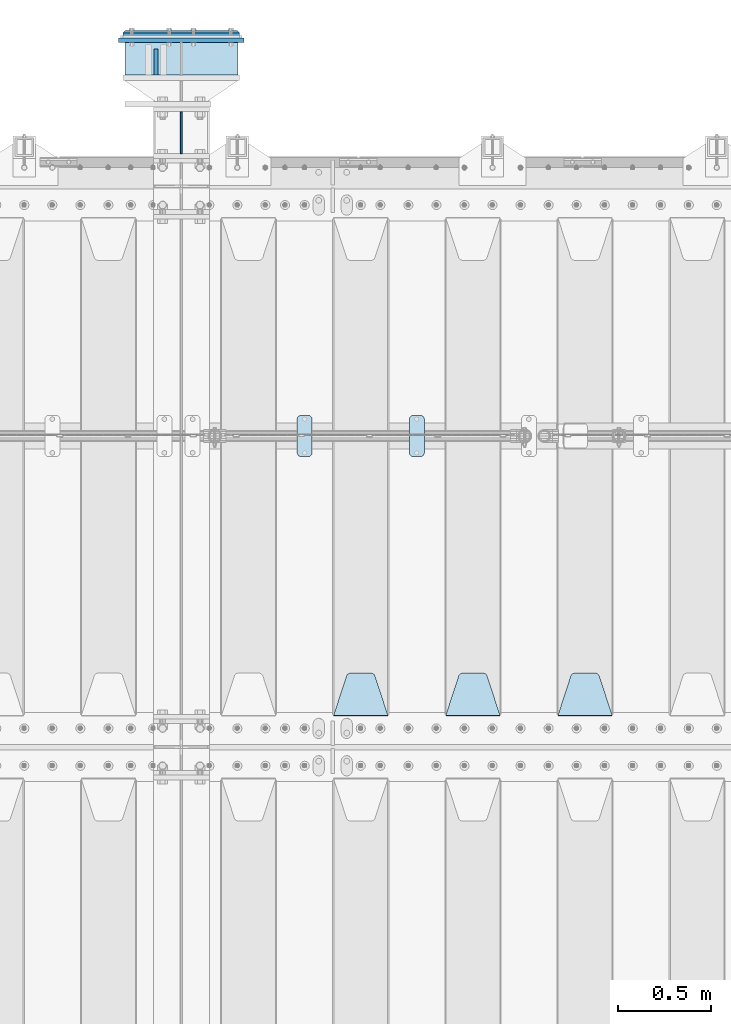
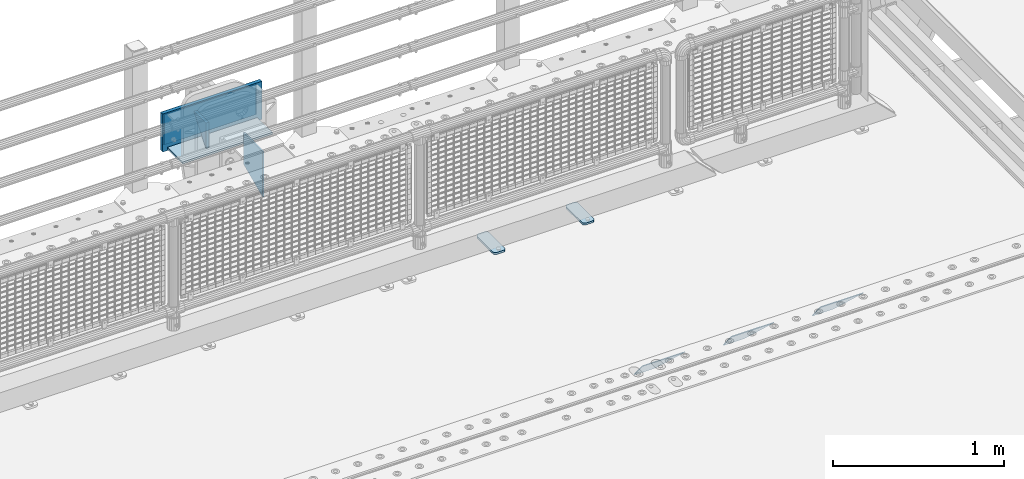
# One storey, part 176 of 193: 10 plates.
"""IFC2X3 building model written with IfcOpenShell, lengths in millimetres."""

from ifc_helpers import new_model, si_unit, frame, origin_with_axes, place, context, subcontext, project, spatial, faceted_brep, material, type_object, element, save


model = new_model("IFC2X3")

# Units and contexts
model_context = context("Model", 3, precision=1e-05, world=origin_with_axes())
body_context = subcontext(model_context, "Body", "Model", "MODEL_VIEW")
ifc_project = project(units=[si_unit("LENGTHUNIT", "METRE", prefix="MILLI"), si_unit("AREAUNIT", "SQUARE_METRE"), si_unit("VOLUMEUNIT", "CUBIC_METRE"), si_unit("MASSUNIT", "GRAM", prefix="KILO"), si_unit("TIMEUNIT", "SECOND"), si_unit("PLANEANGLEUNIT", "RADIAN"), si_unit("SOLIDANGLEUNIT", "STERADIAN"), si_unit("THERMODYNAMICTEMPERATUREUNIT", "DEGREE_CELSIUS"), si_unit("LUMINOUSINTENSITYUNIT", "LUMEN")], contexts=[model_context])

# Site, building, storey
site_placement = place(None, origin_with_axes())
site = spatial("IfcSite", under=ifc_project, at=site_placement, CompositionType="ELEMENT")
building_placement = place(site_placement, origin_with_axes())
building = spatial("IfcBuilding", under=site, at=building_placement, Name="Standard", CompositionType="ELEMENT")
storey_placement = place(building_placement, origin_with_axes())
storey = spatial("IfcBuildingStorey", under=building, at=storey_placement, Name="Undefined", CompositionType="ELEMENT", Elevation=0.0)

# Plates
ifc_material_1 = material(Name="STEEL/S355N")
plate_type_1 = type_object("IfcPlateType", PredefinedType="NOTDEFINED")
plate_1_placement = place(storey_placement, frame((-32195.5000000678, 30735.0000000043, -14.0000182383294), z_axis=(0.0, 0.0, -1.0), x_axis=(0.0, -1.0, 0.0)))
element("IfcPlate", 1, at=plate_1_placement, inside=storey, type_object=plate_type_1, material=ifc_material_1, context=body_context, shape_type="Brep", body=[
    faceted_brep([(0.0, -10.0, 0.0), (140.0, -10.0, 180.0), (140.0, 10.0, 180.0), (0.0, 10.0, 0.0), (140.0, -10.0, -1.81898940354586e-12), (140.0, 10.0, -1.81898940354586e-12)], [[[0, 1, 2, 3]], [[1, 4, 5, 2]], [[4, 0, 3, 5]], [[5, 3, 2]], [[4, 1, 0]]]),
])
plate_type_2 = type_object("IfcPlateType", PredefinedType="NOTDEFINED")
plate_2_placement = place(storey_placement, frame((-29755.0, 27168.232233047, -1.76776695296758), z_axis=(0.0, 0.707106781186547, -0.707106781186548), x_axis=(-1.0, 0.0, 0.0)))
element("IfcPlate", 2, at=plate_2_placement, inside=storey, type_object=plate_type_2, material=ifc_material_1, context=body_context, shape_type="Brep", body=[
    faceted_brep([(0.0, -2.5, 0.0), (69.345504679477, -2.50000000000364, 300.171731424831), (69.345504679477, 2.49999999999636, 300.171731424831), (0.0, 2.5, 0.0), (70.9274061199576, -2.50000000000364, 304.897442415397), (70.9274061199576, 2.49999999999636, 304.897442415397), (73.3818627772307, -2.50000000000364, 309.234538108529), (73.3818627772307, 2.49999999999636, 309.234538108529), (76.6187032999551, -2.50000000000728, 313.023683126103), (76.6187032999551, 2.49999999999636, 313.023683126103), (80.5190132704993, -2.50000000000364, 316.125672595372), (80.5190132704993, 2.49999999999636, 316.125672595368), (84.9395038596849, -2.50000000000364, 318.426546230472), (84.9395038596849, 2.49999999999636, 318.426546230476), (89.7177759439219, -2.50000000000364, 319.841774983273), (89.7177759439219, 2.49999999999636, 319.841774983277), (94.678286292652, -2.50000000000364, 320.319366455074), (94.678286292652, 2.49999999999636, 320.319366455074), (195.321713707348, -2.50000000000364, 320.319366455074), (195.321713707348, 2.49999999999636, 320.319366455074), (200.282224056078, -2.50000000000364, 319.841774983273), (200.282224056078, 2.49999999999636, 319.841774983277), (205.060496140315, -2.50000000000364, 318.426546230472), (205.060496140315, 2.49999999999636, 318.426546230472), (209.480986729501, -2.50000000000364, 316.125672595372), (209.480986729501, 2.49999999999636, 316.125672595368), (213.381296700045, -2.50000000000728, 313.023683126103), (213.381296700045, 2.49999999999272, 313.023683126103), (216.618137222769, -2.50000000000364, 309.234538108525), (216.618137222769, 2.49999999999636, 309.234538108522), (219.072593880042, -2.50000000000364, 304.897442415397), (219.072593880042, 2.49999999999636, 304.897442415397), (220.654495320523, -2.50000000000364, 300.171731424831), (220.654495320523, 2.49999999999636, 300.171731424831), (290.0, -2.50000000000364, 0.0), (290.0, 2.49999999999636, 0.0)], [[[0, 1, 2, 3]], [[1, 4, 5, 2]], [[4, 6, 7, 5]], [[6, 8, 9, 7]], [[8, 10, 11, 9]], [[10, 12, 13, 11]], [[12, 14, 15, 13]], [[14, 16, 17, 15]], [[16, 18, 19, 17]], [[18, 20, 21, 19]], [[20, 22, 23, 21]], [[22, 24, 25, 23]], [[24, 26, 27, 25]], [[26, 28, 29, 27]], [[28, 30, 31, 29]], [[30, 32, 33, 31]], [[32, 34, 35, 33]], [[34, 0, 3, 35]], [[5, 7, 9, 11, 13, 15, 17, 19, 21, 23, 25, 27, 29, 31, 33, 35, 3, 2]], [[34, 32, 30, 28, 26, 24, 22, 20, 18, 16, 14, 12, 10, 8, 6, 4, 1, 0]]]),
])
plate_3_placement = place(storey_placement, frame((-30355.0, 27168.232233047, -1.76776695296758), z_axis=(0.0, 0.707106781186547, -0.707106781186548), x_axis=(-1.0, 0.0, 0.0)))
element("IfcPlate", 3, at=plate_3_placement, inside=storey, type_object=plate_type_2, material=ifc_material_1, context=body_context, shape_type="Brep", body=[
    faceted_brep([(0.0, -2.5, 0.0), (69.345504679477, -2.50000000000364, 300.171731424831), (69.345504679477, 2.49999999999636, 300.171731424831), (0.0, 2.5, 0.0), (70.9274061199576, -2.50000000000364, 304.897442415397), (70.9274061199576, 2.49999999999636, 304.897442415397), (73.3818627772307, -2.50000000000364, 309.234538108529), (73.3818627772307, 2.49999999999636, 309.234538108529), (76.6187032999551, -2.50000000000728, 313.023683126103), (76.6187032999551, 2.49999999999636, 313.023683126103), (80.5190132704993, -2.50000000000364, 316.125672595372), (80.5190132704993, 2.49999999999636, 316.125672595368), (84.9395038596849, -2.50000000000364, 318.426546230472), (84.9395038596849, 2.49999999999636, 318.426546230476), (89.7177759439219, -2.50000000000364, 319.841774983273), (89.7177759439219, 2.49999999999636, 319.841774983277), (94.678286292652, -2.50000000000364, 320.319366455074), (94.678286292652, 2.49999999999636, 320.319366455074), (195.321713707348, -2.50000000000364, 320.319366455074), (195.321713707348, 2.49999999999636, 320.319366455074), (200.282224056078, -2.50000000000364, 319.841774983273), (200.282224056078, 2.49999999999636, 319.841774983277), (205.060496140315, -2.50000000000364, 318.426546230472), (205.060496140315, 2.49999999999636, 318.426546230472), (209.480986729501, -2.50000000000364, 316.125672595372), (209.480986729501, 2.49999999999636, 316.125672595368), (213.381296700045, -2.50000000000728, 313.023683126103), (213.381296700045, 2.49999999999272, 313.023683126103), (216.618137222769, -2.50000000000364, 309.234538108525), (216.618137222769, 2.49999999999636, 309.234538108522), (219.072593880042, -2.50000000000364, 304.897442415397), (219.072593880042, 2.49999999999636, 304.897442415397), (220.654495320523, -2.50000000000364, 300.171731424831), (220.654495320523, 2.49999999999636, 300.171731424831), (290.0, -2.50000000000364, 0.0), (290.0, 2.49999999999636, 0.0)], [[[0, 1, 2, 3]], [[1, 4, 5, 2]], [[4, 6, 7, 5]], [[6, 8, 9, 7]], [[8, 10, 11, 9]], [[10, 12, 13, 11]], [[12, 14, 15, 13]], [[14, 16, 17, 15]], [[16, 18, 19, 17]], [[18, 20, 21, 19]], [[20, 22, 23, 21]], [[22, 24, 25, 23]], [[24, 26, 27, 25]], [[26, 28, 29, 27]], [[28, 30, 31, 29]], [[30, 32, 33, 31]], [[32, 34, 35, 33]], [[34, 0, 3, 35]], [[5, 7, 9, 11, 13, 15, 17, 19, 21, 23, 25, 27, 29, 31, 33, 35, 3, 2]], [[34, 32, 30, 28, 26, 24, 22, 20, 18, 16, 14, 12, 10, 8, 6, 4, 1, 0]]]),
])
plate_4_placement = place(storey_placement, frame((-30955.0, 27168.232233047, -1.76776695296758), z_axis=(0.0, 0.707106781186547, -0.707106781186548), x_axis=(-1.0, 0.0, 0.0)))
element("IfcPlate", 4, at=plate_4_placement, inside=storey, type_object=plate_type_2, material=ifc_material_1, context=body_context, shape_type="Brep", body=[
    faceted_brep([(0.0, -2.5, 0.0), (69.345504679477, -2.50000000000364, 300.171731424831), (69.345504679477, 2.49999999999636, 300.171731424831), (0.0, 2.5, 0.0), (70.9274061199576, -2.50000000000364, 304.897442415397), (70.9274061199576, 2.49999999999636, 304.897442415397), (73.3818627772307, -2.50000000000364, 309.234538108529), (73.3818627772307, 2.49999999999636, 309.234538108529), (76.6187032999551, -2.50000000000728, 313.023683126103), (76.6187032999551, 2.49999999999636, 313.023683126103), (80.5190132704993, -2.50000000000364, 316.125672595372), (80.5190132704993, 2.49999999999636, 316.125672595368), (84.9395038596849, -2.50000000000364, 318.426546230472), (84.9395038596849, 2.49999999999636, 318.426546230476), (89.7177759439219, -2.50000000000364, 319.841774983273), (89.7177759439219, 2.49999999999636, 319.841774983277), (94.678286292652, -2.50000000000364, 320.319366455074), (94.678286292652, 2.49999999999636, 320.319366455074), (195.321713707348, -2.50000000000364, 320.319366455074), (195.321713707348, 2.49999999999636, 320.319366455074), (200.282224056078, -2.50000000000364, 319.841774983273), (200.282224056078, 2.49999999999636, 319.841774983277), (205.060496140315, -2.50000000000364, 318.426546230472), (205.060496140315, 2.49999999999636, 318.426546230472), (209.480986729501, -2.50000000000364, 316.125672595372), (209.480986729501, 2.49999999999636, 316.125672595368), (213.381296700045, -2.50000000000728, 313.023683126103), (213.381296700045, 2.49999999999272, 313.023683126103), (216.618137222769, -2.50000000000364, 309.234538108525), (216.618137222769, 2.49999999999636, 309.234538108522), (219.072593880042, -2.50000000000364, 304.897442415397), (219.072593880042, 2.49999999999636, 304.897442415397), (220.654495320523, -2.50000000000364, 300.171731424831), (220.654495320523, 2.49999999999636, 300.171731424831), (290.0, -2.50000000000364, 0.0), (290.0, 2.49999999999636, 0.0)], [[[0, 1, 2, 3]], [[1, 4, 5, 2]], [[4, 6, 7, 5]], [[6, 8, 9, 7]], [[8, 10, 11, 9]], [[10, 12, 13, 11]], [[12, 14, 15, 13]], [[14, 16, 17, 15]], [[16, 18, 19, 17]], [[18, 20, 21, 19]], [[20, 22, 23, 21]], [[22, 24, 25, 23]], [[24, 26, 27, 25]], [[26, 28, 29, 27]], [[28, 30, 31, 29]], [[30, 32, 33, 31]], [[32, 34, 35, 33]], [[34, 0, 3, 35]], [[5, 7, 9, 11, 13, 15, 17, 19, 21, 23, 25, 27, 29, 31, 33, 35, 3, 2]], [[34, 32, 30, 28, 26, 24, 22, 20, 18, 16, 14, 12, 10, 8, 6, 4, 1, 0]]]),
])
ifc_material_2 = material()
plate_type_3 = type_object("IfcPlateType", PredefinedType="NOTDEFINED")
plate_5_placement = place(storey_placement, frame((-31757.5000000678, 30595.0000000043, -243.000018238358), z_axis=(0.0, 1.0, 0.0), x_axis=(-1.0, 0.0, 0.0)))
element("IfcPlate", 5, at=plate_5_placement, inside=storey, type_object=plate_type_3, material=ifc_material_2, context=body_context, shape_type="Brep", body=[
    faceted_brep([(0.0, -7.0, 0.0), (0.0, -7.0, 175.0), (0.0, 7.0, 175.0), (0.0, 7.0, 0.0), (605.0, -7.0, 175.0), (605.0, 7.0, 175.0), (605.0, -7.0, 0.0), (605.0, 7.0, 0.0)], [[[0, 1, 2, 3]], [[1, 4, 5, 2]], [[4, 6, 7, 5]], [[6, 0, 3, 7]], [[5, 7, 3, 2]], [[6, 4, 1, 0]]]),
])
ifc_material_3 = material()
plate_type_4 = type_object("IfcPlateType", PredefinedType="NOTDEFINED")
plate_6_placement = place(storey_placement, frame((-31747.5000000678, 30815.0000000043, -12.5000182383585), z_axis=(0.0, 0.0, -1.0), x_axis=(-1.0, 0.0, 0.0)))
element("IfcPlate", 6, at=plate_6_placement, inside=storey, type_object=plate_type_4, material=ifc_material_3, context=body_context, shape_type="Brep", body=[
    faceted_brep([(0.0, -15.0, 0.0), (5.0, -20.0, 5.0), (5.0, -20.0, 220.0), (0.0, -15.0, 225.0), (625.0, -15.0, 0.0), (620.0, -20.0, 5.0), (620.0, -20.0, 220.0), (625.0, -15.0, 225.0), (15.0, 20.0, 15.0), (0.0, 5.0, 0.0), (0.0, 5.0, 225.0), (15.0, 20.0, 210.0), (625.0, 5.0, 225.0), (610.0, 20.0, 210.0), (625.0, 5.0, 0.0), (610.0, 20.0, 15.0), (64.8205080756888, -5.0, 37.5), (57.5, -5.0, 30.1794919243112), (47.5, -5.0, 27.5), (37.5, -5.0, 30.1794919243112), (30.1794919243112, -5.0, 37.5), (27.5, -5.0, 47.5), (30.1794919243112, -5.0, 57.5), (37.5, -5.0, 64.8205080756888), (47.5, -5.0, 67.5), (57.5, -5.0, 64.8205080756888), (64.8205080756888, -5.0, 57.5), (67.5, -5.0, 47.5), (37.5, 20.0, 64.8205080756888), (30.1794919243112, 20.0, 57.5), (47.5, 20.0, 67.5), (57.5, 20.0, 64.8205080756888), (64.8205080756888, 20.0, 57.5), (67.5, 20.0, 47.5), (64.8205080756888, 20.0, 37.5), (57.5, 20.0, 30.1794919243112), (47.5, 20.0, 27.5), (37.5, 20.0, 30.1794919243112), (30.1794919243112, 20.0, 37.5), (27.5, 20.0, 47.5), (264.820508075689, -5.0, 37.5), (257.5, -5.0, 30.1794919243112), (247.5, -5.0, 27.5), (237.5, -5.0, 30.1794919243112), (230.179491924311, -5.0, 37.5), (227.5, -5.0, 47.5), (230.179491924311, -5.0, 57.5), (237.5, -5.0, 64.8205080756888), (247.5, -5.0, 67.5), (257.5, -5.0, 64.8205080756888), (264.820508075689, -5.0, 57.5), (267.5, -5.0, 47.5), (230.179491924311, 20.0, 57.5), (227.5, 20.0, 47.5), (237.5, 20.0, 64.8205080756888), (247.5, 20.0, 67.5), (257.5, 20.0, 64.8205080756888), (264.820508075689, 20.0, 57.5), (267.5, 20.0, 47.5), (264.820508075689, 20.0, 37.5), (257.5, 20.0, 30.1794919243112), (247.5, 20.0, 27.5), (237.5, 20.0, 30.1794919243112), (230.179491924311, 20.0, 37.5), (594.820508075689, -5.0, 37.5), (587.5, -5.0, 30.1794919243112), (577.5, -5.0, 27.5), (567.5, -5.0, 30.1794919243112), (560.179491924311, -5.0, 37.5), (557.5, -5.0, 47.5), (560.179491924311, -5.0, 57.5), (567.5, -5.0, 64.8205080756888), (577.5, -5.0, 67.5), (587.5, -5.0, 64.8205080756888), (594.820508075689, -5.0, 57.5), (597.5, -5.0, 47.5), (560.179491924311, 20.0, 57.5), (557.5, 20.0, 47.5), (567.5, 20.0, 64.8205080756888), (577.5, 20.0, 67.5), (587.5, 20.0, 64.8205080756888), (594.820508075689, 20.0, 57.5), (597.5, 20.0, 47.5), (594.820508075689, 20.0, 37.5), (587.5, 20.0, 30.1794919243112), (577.5, 20.0, 27.5), (567.5, 20.0, 30.1794919243112), (560.179491924311, 20.0, 37.5), (594.820508075689, -5.0, 167.5), (587.5, -5.0, 160.179491924311), (577.5, -5.0, 157.5), (567.5, -5.0, 160.179491924311), (560.179491924311, -5.0, 167.5), (557.5, -5.0, 177.5), (560.179491924311, -5.0, 187.5), (567.5, -5.0, 194.820508075689), (577.5, -5.0, 197.5), (587.5, -5.0, 194.820508075689), (594.820508075689, -5.0, 187.5), (597.5, -5.0, 177.5), (560.179491924311, 20.0, 187.5), (557.5, 20.0, 177.5), (567.5, 20.0, 194.820508075689), (577.5, 20.0, 197.5), (587.5, 20.0, 194.820508075689), (594.820508075689, 20.0, 187.5), (597.5, 20.0, 177.5), (594.820508075689, 20.0, 167.5), (587.5, 20.0, 160.179491924311), (577.5, 20.0, 157.5), (567.5, 20.0, 160.179491924311), (560.179491924311, 20.0, 167.5), (264.820508075689, -5.0, 167.5), (257.5, -5.0, 160.179491924311), (247.5, -5.0, 157.5), (237.5, -5.0, 160.179491924311), (230.179491924311, -5.0, 167.5), (227.5, -5.0, 177.5), (230.179491924311, -5.0, 187.5), (237.5, -5.0, 194.820508075689), (247.5, -5.0, 197.5), (257.5, -5.0, 194.820508075689), (264.820508075689, -5.0, 187.5), (267.5, -5.0, 177.5), (230.179491924311, 20.0, 187.5), (227.5, 20.0, 177.5), (237.5, 20.0, 194.820508075689), (247.5, 20.0, 197.5), (257.5, 20.0, 194.820508075689), (264.820508075689, 20.0, 187.5), (267.5, 20.0, 177.5), (264.820508075689, 20.0, 167.5), (257.5, 20.0, 160.179491924311), (247.5, 20.0, 157.5), (237.5, 20.0, 160.179491924311), (230.179491924311, 20.0, 167.5), (64.8205080756888, -5.0, 167.5), (57.5, -5.0, 160.179491924311), (47.5, -5.0, 157.5), (37.5, -5.0, 160.179491924311), (30.1794919243112, -5.0, 167.5), (27.5, -5.0, 177.5), (30.1794919243112, -5.0, 187.5), (37.5, -5.0, 194.820508075689), (47.5, -5.0, 197.5), (57.5, -5.0, 194.820508075689), (64.8205080756888, -5.0, 187.5), (67.5, -5.0, 177.5), (30.1794919243112, 20.0, 187.5), (27.5, 20.0, 177.5), (37.5, 20.0, 194.820508075689), (47.5, 20.0, 197.5), (57.5, 20.0, 194.820508075689), (64.8205080756888, 20.0, 187.5), (67.5, 20.0, 177.5), (64.8205080756888, 20.0, 167.5), (57.5, 20.0, 160.179491924311), (47.5, 20.0, 157.5), (37.5, 20.0, 160.179491924311), (30.1794919243112, 20.0, 167.5), (394.820508075689, -5.0, 167.5), (387.5, -5.0, 160.179491924311), (377.5, -5.0, 157.5), (367.5, -5.0, 160.179491924311), (360.179491924311, -5.0, 167.5), (357.5, -5.0, 177.5), (360.179491924311, -5.0, 187.5), (367.5, -5.0, 194.820508075689), (377.5, -5.0, 197.5), (387.5, -5.0, 194.820508075689), (394.820508075689, -5.0, 187.5), (397.5, -5.0, 177.5), (360.179491924311, 20.0, 187.5), (357.5, 20.0, 177.5), (367.5, 20.0, 194.820508075689), (377.5, 20.0, 197.5), (387.5, 20.0, 194.820508075689), (394.820508075689, 20.0, 187.5), (397.5, 20.0, 177.5), (394.820508075689, 20.0, 167.5), (387.5, 20.0, 160.179491924311), (377.5, 20.0, 157.5), (367.5, 20.0, 160.179491924311), (360.179491924311, 20.0, 167.5), (394.820508075689, -5.0, 37.5), (387.5, -5.0, 30.1794919243112), (377.5, -5.0, 27.5), (367.5, -5.0, 30.1794919243112), (360.179491924311, -5.0, 37.5), (357.5, -5.0, 47.5), (360.179491924311, -5.0, 57.5), (367.5, -5.0, 64.8205080756888), (377.5, -5.0, 67.5), (387.5, -5.0, 64.8205080756888), (394.820508075689, -5.0, 57.5), (397.5, -5.0, 47.5), (360.179491924311, 20.0, 57.5), (357.5, 20.0, 47.5), (367.5, 20.0, 64.8205080756888), (377.5, 20.0, 67.5), (387.5, 20.0, 64.8205080756888), (394.820508075689, 20.0, 57.5), (397.5, 20.0, 47.5), (394.820508075689, 20.0, 37.5), (387.5, 20.0, 30.1794919243112), (377.5, 20.0, 27.5), (367.5, 20.0, 30.1794919243112), (360.179491924311, 20.0, 37.5)], [[[0, 1, 2, 3]], [[4, 5, 1, 0]], [[6, 7, 3, 2]], [[7, 6, 5, 4]], [[8, 9, 10, 11]], [[12, 13, 11, 10]], [[14, 15, 13, 12]], [[15, 14, 9, 8]], [[16, 17, 18, 19, 20, 21, 22, 23, 24, 25, 26, 27]], [[28, 23, 22, 29]], [[30, 24, 23, 28]], [[31, 25, 24, 30]], [[32, 26, 25, 31]], [[33, 27, 26, 32]], [[34, 16, 27, 33]], [[35, 17, 16, 34]], [[36, 18, 17, 35]], [[37, 19, 18, 36]], [[38, 20, 19, 37]], [[39, 21, 20, 38]], [[29, 22, 21, 39]], [[5, 6, 2, 1]], [[9, 14, 4, 0]], [[14, 12, 7, 4]], [[12, 10, 3, 7]], [[10, 9, 0, 3]], [[40, 41, 42, 43, 44, 45, 46, 47, 48, 49, 50, 51]], [[52, 46, 45, 53]], [[54, 47, 46, 52]], [[55, 48, 47, 54]], [[56, 49, 48, 55]], [[57, 50, 49, 56]], [[58, 51, 50, 57]], [[59, 40, 51, 58]], [[60, 41, 40, 59]], [[61, 42, 41, 60]], [[62, 43, 42, 61]], [[63, 44, 43, 62]], [[53, 45, 44, 63]], [[64, 65, 66, 67, 68, 69, 70, 71, 72, 73, 74, 75]], [[76, 70, 69, 77]], [[78, 71, 70, 76]], [[79, 72, 71, 78]], [[80, 73, 72, 79]], [[81, 74, 73, 80]], [[82, 75, 74, 81]], [[83, 64, 75, 82]], [[84, 65, 64, 83]], [[85, 66, 65, 84]], [[86, 67, 66, 85]], [[87, 68, 67, 86]], [[77, 69, 68, 87]], [[88, 89, 90, 91, 92, 93, 94, 95, 96, 97, 98, 99]], [[100, 94, 93, 101]], [[102, 95, 94, 100]], [[103, 96, 95, 102]], [[104, 97, 96, 103]], [[105, 98, 97, 104]], [[106, 99, 98, 105]], [[107, 88, 99, 106]], [[108, 89, 88, 107]], [[109, 90, 89, 108]], [[110, 91, 90, 109]], [[111, 92, 91, 110]], [[101, 93, 92, 111]], [[112, 113, 114, 115, 116, 117, 118, 119, 120, 121, 122, 123]], [[124, 118, 117, 125]], [[126, 119, 118, 124]], [[127, 120, 119, 126]], [[128, 121, 120, 127]], [[129, 122, 121, 128]], [[130, 123, 122, 129]], [[131, 112, 123, 130]], [[132, 113, 112, 131]], [[133, 114, 113, 132]], [[134, 115, 114, 133]], [[135, 116, 115, 134]], [[125, 117, 116, 135]], [[136, 137, 138, 139, 140, 141, 142, 143, 144, 145, 146, 147]], [[148, 142, 141, 149]], [[150, 143, 142, 148]], [[151, 144, 143, 150]], [[152, 145, 144, 151]], [[153, 146, 145, 152]], [[154, 147, 146, 153]], [[155, 136, 147, 154]], [[156, 137, 136, 155]], [[157, 138, 137, 156]], [[158, 139, 138, 157]], [[159, 140, 139, 158]], [[149, 141, 140, 159]], [[160, 161, 162, 163, 164, 165, 166, 167, 168, 169, 170, 171]], [[172, 166, 165, 173]], [[174, 167, 166, 172]], [[175, 168, 167, 174]], [[176, 169, 168, 175]], [[177, 170, 169, 176]], [[178, 171, 170, 177]], [[179, 160, 171, 178]], [[180, 161, 160, 179]], [[181, 162, 161, 180]], [[182, 163, 162, 181]], [[183, 164, 163, 182]], [[173, 165, 164, 183]], [[184, 185, 186, 187, 188, 189, 190, 191, 192, 193, 194, 195]], [[196, 190, 189, 197]], [[198, 191, 190, 196]], [[199, 192, 191, 198]], [[200, 193, 192, 199]], [[201, 194, 193, 200]], [[202, 195, 194, 201]], [[203, 184, 195, 202]], [[204, 185, 184, 203]], [[205, 186, 185, 204]], [[206, 187, 186, 205]], [[207, 188, 187, 206]], [[197, 189, 188, 207]], [[13, 15, 8, 11], [37, 36, 35, 34, 33, 32, 31, 30, 28, 29, 39, 38], [206, 205, 204, 203, 202, 201, 200, 199, 198, 196, 197, 207], [182, 181, 180, 179, 178, 177, 176, 175, 174, 172, 173, 183], [158, 157, 156, 155, 154, 153, 152, 151, 150, 148, 149, 159], [134, 133, 132, 131, 130, 129, 128, 127, 126, 124, 125, 135], [110, 109, 108, 107, 106, 105, 104, 103, 102, 100, 101, 111], [86, 85, 84, 83, 82, 81, 80, 79, 78, 76, 77, 87], [62, 61, 60, 59, 58, 57, 56, 55, 54, 52, 53, 63]]]),
])
plate_type_5 = type_object("IfcPlateType", PredefinedType="NOTDEFINED")
plate_7_placement = place(storey_placement, frame((-31725.0000000678, 30782.5000000043, 9.99998176164149), z_axis=(0.0, 0.0, -1.0), x_axis=(-1.0, 0.0, 0.0)))
element("IfcPlate", 7, at=plate_7_placement, inside=storey, type_object=plate_type_5, material=ifc_material_1, context=body_context, shape_type="Brep", body=[
    faceted_brep([(0.0, -12.5, 0.0), (0.0, -12.5, 270.0), (0.0, 12.5, 270.0), (0.0, 12.5, 0.0), (670.0, -12.5, 270.0), (670.0, 12.5, 270.0), (670.0, -12.5, 0.0), (670.0, 12.5, 0.0)], [[[0, 1, 2, 3]], [[1, 4, 5, 2]], [[4, 6, 7, 5]], [[6, 0, 3, 7]], [[5, 7, 3, 2]], [[6, 4, 1, 0]]]),
])
plate_type_6 = type_object("IfcPlateType", PredefinedType="NOTDEFINED")
plate_8_placement = place(storey_placement, frame((-32060.0000000678, 30175.0000000043, -336.000018238358), z_axis=(0.0, 1.0, 0.0), x_axis=(0.0, 0.0, 1.0)))
element("IfcPlate", 8, at=plate_8_placement, inside=storey, type_object=plate_type_6, material=ifc_material_1, context=body_context, shape_type="Brep", body=[
    faceted_brep([(0.0, -5.0, 0.0), (100.0, -5.0, 225.0), (100.0, 5.0, 225.0), (0.0, 5.0, 0.0), (322.0, -5.0, 225.0), (322.0, 5.0, 225.0), (322.0, -5.0, 0.0), (322.0, 5.0, 0.0)], [[[0, 1, 2, 3]], [[1, 4, 5, 2]], [[4, 6, 7, 5]], [[6, 0, 3, 7]], [[5, 7, 3, 2]], [[6, 4, 1, 0]]]),
])
ifc_material_4 = material(Name="STEEL/S355J2")
plate_type_7 = type_object("IfcPlateType", PredefinedType="NOTDEFINED")
plate_9_placement = place(storey_placement, frame((-30840.0, 28774.5, 21.0199999999977), z_axis=(1.0, 0.0, 0.0), x_axis=(0.0, -1.0, 0.0)))
element("IfcPlate", 9, at=plate_9_placement, inside=storey, type_object=plate_type_7, material=ifc_material_4, context=body_context, shape_type="Brep", body=[
    faceted_brep([(0.0, -7.0, 20.0), (0.0, -7.0, 60.0), (0.0, 7.0, 60.0), (0.0, 7.0, 20.0), (0.384294391937146, -7.0, 63.9018064403208), (0.384294391937146, 7.0, 63.9018064403208), (1.52240934977453, -7.0, 67.6536686473009), (1.52240934977453, 7.0, 67.6536686473009), (3.37060775395003, -7.0, 71.1114046603907), (3.37060775395003, 7.0, 71.1114046603907), (5.8578643762703, -7.0, 74.1421356237297), (5.8578643762703, 7.0, 74.1421356237297), (8.88859533960931, -7.0, 76.62939224605), (8.88859533960931, 7.0, 76.62939224605), (12.3463313526991, -7.0, 78.4775906502255), (12.3463313526991, 7.0, 78.4775906502255), (16.0981935596792, -7.0, 79.6157056080629), (16.0981935596792, 7.0, 79.6157056080629), (20.0, -7.0, 80.0), (20.0, 7.0, 80.0), (200.0, -7.0, 80.0), (200.0, 7.0, 80.0), (203.901806440321, -7.0, 79.6157056080629), (203.901806440321, 7.0, 79.6157056080629), (207.653668647301, -7.0, 78.4775906502255), (207.653668647301, 7.0, 78.4775906502255), (211.111404660391, -7.0, 76.62939224605), (211.111404660391, 7.0, 76.62939224605), (214.14213562373, -7.0, 74.1421356237297), (214.14213562373, 7.0, 74.1421356237297), (216.62939224605, -7.0, 71.1114046603907), (216.62939224605, 7.0, 71.1114046603907), (218.477590650225, -7.0, 67.6536686473009), (218.477590650225, 7.0, 67.6536686473009), (219.615705608063, -7.0, 63.9018064403208), (219.615705608063, 7.0, 63.9018064403208), (220.0, -7.0, 60.0), (220.0, 7.0, 60.0), (220.0, -7.0, 20.0), (220.0, 7.0, 20.0), (219.615705608063, -7.0, 16.0981935596792), (219.615705608063, 7.0, 16.0981935596792), (218.477590650225, -7.0, 12.3463313526991), (218.477590650225, 7.0, 12.3463313526991), (216.62939224605, -7.0, 8.88859533960931), (216.62939224605, 7.0, 8.88859533960931), (214.14213562373, -7.0, 5.8578643762703), (214.14213562373, 7.0, 5.8578643762703), (211.111404660391, -7.0, 3.37060775395003), (211.111404660391, 7.0, 3.37060775395003), (207.653668647301, -7.0, 1.52240934977453), (207.653668647301, 7.0, 1.52240934977453), (203.901806440321, -7.0, 0.384294391937146), (203.901806440321, 7.0, 0.384294391937146), (200.0, -7.0, 0.0), (200.0, 7.0, 0.0), (20.0, -7.0, 0.0), (20.0, 7.0, 0.0), (16.0981935596792, -7.0, 0.384294391937146), (16.0981935596792, 7.0, 0.384294391937146), (12.3463313526991, -7.0, 1.52240934977453), (12.3463313526991, 7.0, 1.52240934977453), (8.88859533960931, -7.0, 3.37060775395003), (8.88859533960931, 7.0, 3.37060775395003), (5.8578643762703, -7.0, 5.8578643762703), (5.8578643762703, 7.0, 5.8578643762703), (3.37060775395003, -7.0, 8.88859533960931), (3.37060775395003, 7.0, 8.88859533960931), (1.52240934977453, -7.0, 12.3463313526991), (1.52240934977453, 7.0, 12.3463313526991), (0.384294391937146, -7.0, 16.0981935596792), (0.384294391937146, 7.0, 16.0981935596792)], [[[0, 1, 2, 3]], [[1, 4, 5, 2]], [[4, 6, 7, 5]], [[6, 8, 9, 7]], [[8, 10, 11, 9]], [[10, 12, 13, 11]], [[12, 14, 15, 13]], [[14, 16, 17, 15]], [[16, 18, 19, 17]], [[18, 20, 21, 19]], [[20, 22, 23, 21]], [[22, 24, 25, 23]], [[24, 26, 27, 25]], [[26, 28, 29, 27]], [[28, 30, 31, 29]], [[30, 32, 33, 31]], [[32, 34, 35, 33]], [[34, 36, 37, 35]], [[36, 38, 39, 37]], [[38, 40, 41, 39]], [[40, 42, 43, 41]], [[42, 44, 45, 43]], [[44, 46, 47, 45]], [[46, 48, 49, 47]], [[48, 50, 51, 49]], [[50, 52, 53, 51]], [[52, 54, 55, 53]], [[54, 56, 57, 55]], [[56, 58, 59, 57]], [[58, 60, 61, 59]], [[60, 62, 63, 61]], [[62, 64, 65, 63]], [[64, 66, 67, 65]], [[66, 68, 69, 67]], [[68, 70, 71, 69]], [[70, 0, 3, 71]], [[5, 7, 9, 11, 13, 15, 17, 19, 21, 23, 25, 27, 29, 31, 33, 35, 37, 39, 41, 43, 45, 47, 49, 51, 53, 55, 57, 59, 61, 63, 65, 67, 69, 71, 3, 2]], [[70, 68, 66, 64, 62, 60, 58, 56, 54, 52, 50, 48, 46, 44, 42, 40, 38, 36, 34, 32, 30, 28, 26, 24, 22, 20, 18, 16, 14, 12, 10, 8, 6, 4, 1, 0]]]),
])
plate_10_placement = place(storey_placement, frame((-31440.0, 28774.5, 21.0199999999977), z_axis=(1.0, 0.0, 0.0), x_axis=(0.0, -1.0, 0.0)))
element("IfcPlate", 10, at=plate_10_placement, inside=storey, type_object=plate_type_7, material=ifc_material_4, context=body_context, shape_type="Brep", body=[
    faceted_brep([(0.0, -7.0, 20.0), (0.0, -7.0, 60.0), (0.0, 7.0, 60.0), (0.0, 7.0, 20.0), (0.384294391937146, -7.0, 63.9018064403208), (0.384294391937146, 7.0, 63.9018064403208), (1.52240934977453, -7.0, 67.6536686473009), (1.52240934977453, 7.0, 67.6536686473009), (3.37060775395003, -7.0, 71.1114046603907), (3.37060775395003, 7.0, 71.1114046603907), (5.8578643762703, -7.0, 74.1421356237297), (5.8578643762703, 7.0, 74.1421356237297), (8.88859533960931, -7.0, 76.62939224605), (8.88859533960931, 7.0, 76.62939224605), (12.3463313526991, -7.0, 78.4775906502255), (12.3463313526991, 7.0, 78.4775906502255), (16.0981935596792, -7.0, 79.6157056080629), (16.0981935596792, 7.0, 79.6157056080629), (20.0, -7.0, 80.0), (20.0, 7.0, 80.0), (200.0, -7.0, 80.0), (200.0, 7.0, 80.0), (203.901806440321, -7.0, 79.6157056080629), (203.901806440321, 7.0, 79.6157056080629), (207.653668647301, -7.0, 78.4775906502255), (207.653668647301, 7.0, 78.4775906502255), (211.111404660391, -7.0, 76.62939224605), (211.111404660391, 7.0, 76.62939224605), (214.14213562373, -7.0, 74.1421356237297), (214.14213562373, 7.0, 74.1421356237297), (216.62939224605, -7.0, 71.1114046603907), (216.62939224605, 7.0, 71.1114046603907), (218.477590650225, -7.0, 67.6536686473009), (218.477590650225, 7.0, 67.6536686473009), (219.615705608063, -7.0, 63.9018064403208), (219.615705608063, 7.0, 63.9018064403208), (220.0, -7.0, 60.0), (220.0, 7.0, 60.0), (220.0, -7.0, 20.0), (220.0, 7.0, 20.0), (219.615705608063, -7.0, 16.0981935596792), (219.615705608063, 7.0, 16.0981935596792), (218.477590650225, -7.0, 12.3463313526991), (218.477590650225, 7.0, 12.3463313526991), (216.62939224605, -7.0, 8.88859533960931), (216.62939224605, 7.0, 8.88859533960931), (214.14213562373, -7.0, 5.8578643762703), (214.14213562373, 7.0, 5.8578643762703), (211.111404660391, -7.0, 3.37060775395003), (211.111404660391, 7.0, 3.37060775395003), (207.653668647301, -7.0, 1.52240934977453), (207.653668647301, 7.0, 1.52240934977453), (203.901806440321, -7.0, 0.384294391937146), (203.901806440321, 7.0, 0.384294391937146), (200.0, -7.0, 0.0), (200.0, 7.0, 0.0), (20.0, -7.0, 0.0), (20.0, 7.0, 0.0), (16.0981935596792, -7.0, 0.384294391937146), (16.0981935596792, 7.0, 0.384294391937146), (12.3463313526991, -7.0, 1.52240934977453), (12.3463313526991, 7.0, 1.52240934977453), (8.88859533960931, -7.0, 3.37060775395003), (8.88859533960931, 7.0, 3.37060775395003), (5.8578643762703, -7.0, 5.8578643762703), (5.8578643762703, 7.0, 5.8578643762703), (3.37060775395003, -7.0, 8.88859533960931), (3.37060775395003, 7.0, 8.88859533960931), (1.52240934977453, -7.0, 12.3463313526991), (1.52240934977453, 7.0, 12.3463313526991), (0.384294391937146, -7.0, 16.0981935596792), (0.384294391937146, 7.0, 16.0981935596792)], [[[0, 1, 2, 3]], [[1, 4, 5, 2]], [[4, 6, 7, 5]], [[6, 8, 9, 7]], [[8, 10, 11, 9]], [[10, 12, 13, 11]], [[12, 14, 15, 13]], [[14, 16, 17, 15]], [[16, 18, 19, 17]], [[18, 20, 21, 19]], [[20, 22, 23, 21]], [[22, 24, 25, 23]], [[24, 26, 27, 25]], [[26, 28, 29, 27]], [[28, 30, 31, 29]], [[30, 32, 33, 31]], [[32, 34, 35, 33]], [[34, 36, 37, 35]], [[36, 38, 39, 37]], [[38, 40, 41, 39]], [[40, 42, 43, 41]], [[42, 44, 45, 43]], [[44, 46, 47, 45]], [[46, 48, 49, 47]], [[48, 50, 51, 49]], [[50, 52, 53, 51]], [[52, 54, 55, 53]], [[54, 56, 57, 55]], [[56, 58, 59, 57]], [[58, 60, 61, 59]], [[60, 62, 63, 61]], [[62, 64, 65, 63]], [[64, 66, 67, 65]], [[66, 68, 69, 67]], [[68, 70, 71, 69]], [[70, 0, 3, 71]], [[5, 7, 9, 11, 13, 15, 17, 19, 21, 23, 25, 27, 29, 31, 33, 35, 37, 39, 41, 43, 45, 47, 49, 51, 53, 55, 57, 59, 61, 63, 65, 67, 69, 71, 3, 2]], [[70, 68, 66, 64, 62, 60, 58, 56, 54, 52, 50, 48, 46, 44, 42, 40, 38, 36, 34, 32, 30, 28, 26, 24, 22, 20, 18, 16, 14, 12, 10, 8, 6, 4, 1, 0]]]),
])

save(model, "model.ifc")
